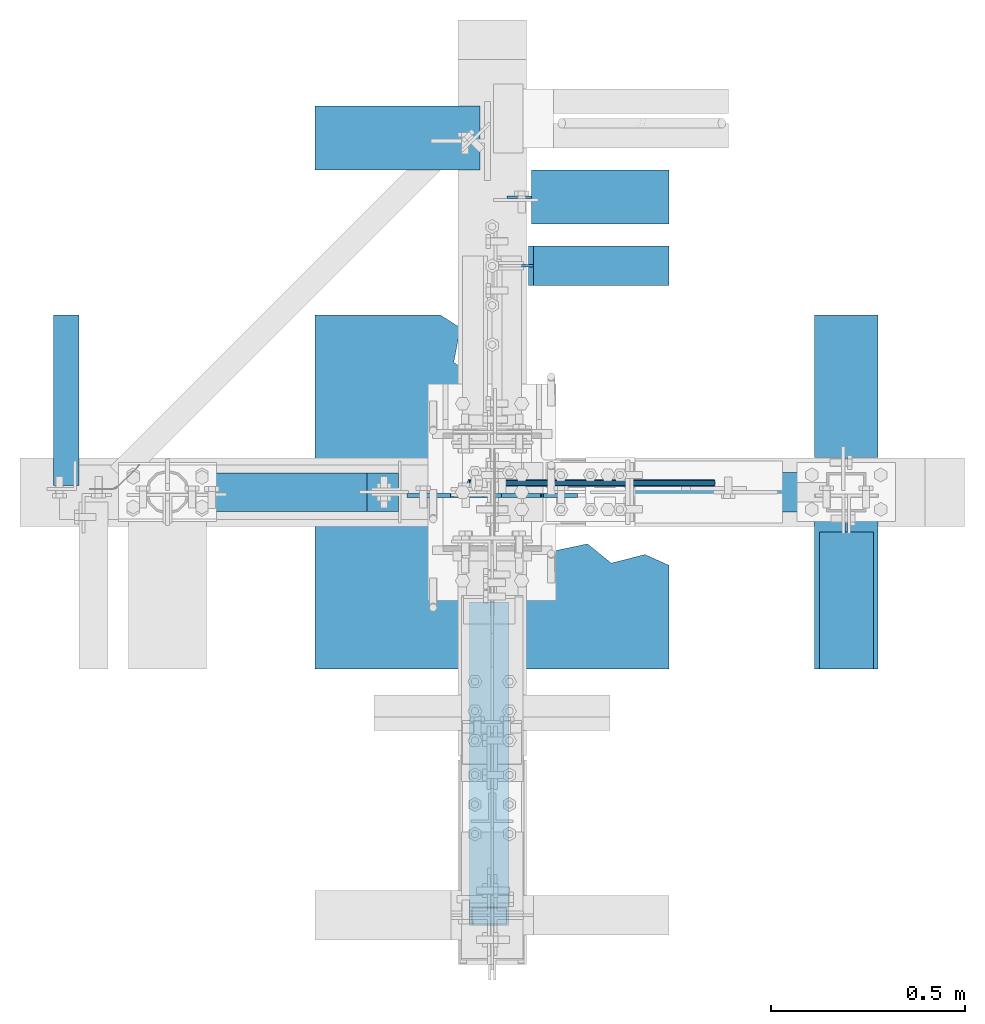
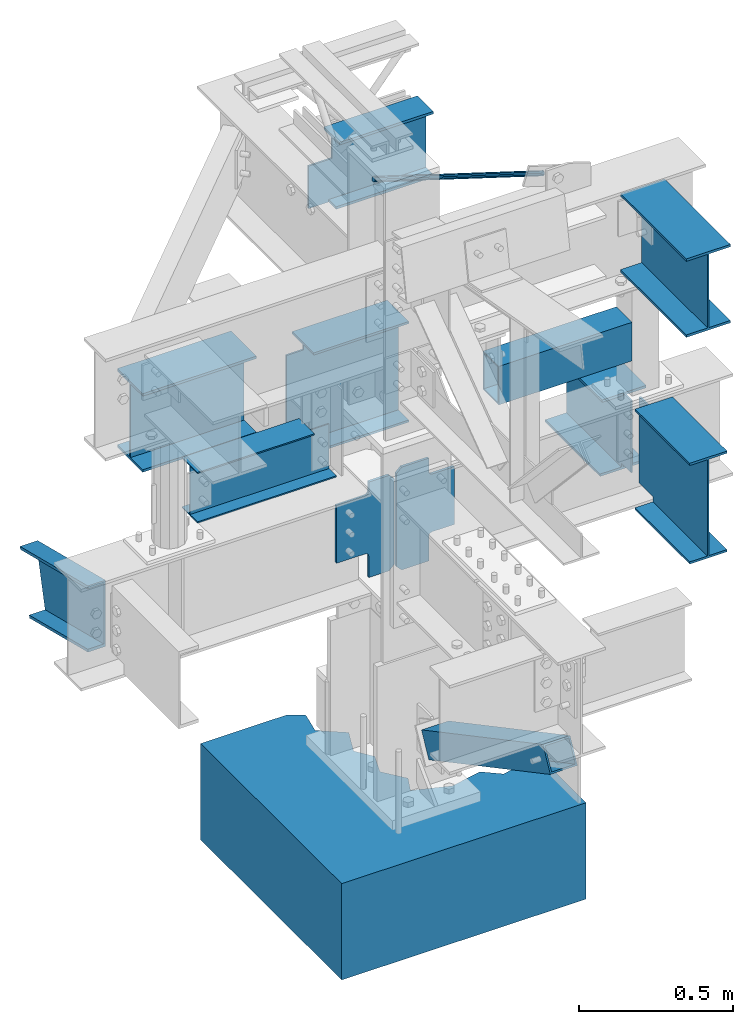
# Not in any storey, part 8 of 8: 8 beams, 3 members, 3 plates, 13 elements without a shape of their own.
"""IFC2X3 building model written with IfcOpenShell, lengths in inches."""

from ifc_helpers import new_model, entity, si_unit, converted_unit, frame, origin_with_axes, place, context, project, spatial, faceted_brep, source, transform, mapped, material, type_object, type_shapes, element, aggregate, save


model = new_model("IFC2X3")

# Units and contexts
model_context = context("Model", 3, precision=1e-05, world=origin_with_axes())
ifc_project = project(units=[converted_unit("LENGTHUNIT", "INCH", entity("IfcLengthMeasure", 25.4), si_unit("LENGTHUNIT", "METRE", prefix="MILLI"), dimensions=[1, 0, 0, 0, 0, 0, 0]), si_unit("PLANEANGLEUNIT", "RADIAN"), si_unit("MASSUNIT", "GRAM", prefix="KILO"), si_unit("TIMEUNIT", "SECOND"), si_unit("AREAUNIT", "SQUARE_METRE"), si_unit("PRESSUREUNIT", "PASCAL"), si_unit("FORCEUNIT", "NEWTON"), si_unit("THERMODYNAMICTEMPERATUREUNIT", "DEGREE_CELSIUS")], contexts=[model_context])

# Site, building
site_placement = place(None, origin_with_axes())
site = spatial("IfcSite", under=ifc_project, at=site_placement, CompositionType="ELEMENT")
building_placement = place(site_placement, origin_with_axes())
building = spatial("IfcBuilding", under=site, at=building_placement, Name="Building", CompositionType="ELEMENT")

# Assembly, member
assembly_1_placement = place(building_placement, frame((23.9999999999998, 0.9375, 83.0), z_axis=(0.0, 1.0, 0.0), x_axis=(-0.954479957764932, 0.0, 0.29827505800024)))
assembly_1 = element("IfcElementAssembly", 1, at=assembly_1_placement, inside=building, Name="4-7", PredefinedType="NOTDEFINED")
ifc_material_1 = material()
member_type_1 = type_object("IfcMemberType", Name="RB3/4", PredefinedType="BRACE", material=ifc_material_1)
shared_shape_1 = source(origin_with_axes(), model_context, "Body", "Brep", [
    faceted_brep([(0.0, 0.0, 0.375), (26.1446, 0.0, 0.375), (26.1446, 0.1875, 0.325), (0.0, 0.1875, 0.325), (26.1446, 0.3248, 0.187), (0.0, 0.3248, 0.187), (26.1446, 0.375, 0.0), (0.0, 0.375, 0.0), (26.1446, 0.3248, -0.188), (0.0, 0.3248, -0.188), (26.1446, 0.1875, -0.325), (0.0, 0.1875, -0.325), (26.1446, 0.0, -0.375), (0.0, 0.0, -0.375), (26.1446, -0.1875, -0.325), (0.0, -0.1875, -0.325), (26.1446, -0.3248, -0.187), (0.0, -0.3248, -0.187), (26.1446, -0.375, 0.0), (0.0, -0.375, 0.0), (26.1446, -0.3248, 0.188), (0.0, -0.3248, 0.188), (26.1446, -0.1875, 0.325), (0.0, -0.1875, 0.325)], [[[0, 1, 2, 3]], [[3, 2, 4, 5]], [[5, 4, 6, 7]], [[7, 6, 8, 9]], [[9, 8, 10, 11]], [[11, 10, 12, 13]], [[13, 12, 14, 15]], [[15, 14, 16, 17]], [[17, 16, 18, 19]], [[19, 18, 20, 21]], [[21, 20, 22, 23]], [[23, 22, 1, 0]], [[0, 3, 5, 7, 9, 11, 13, 15, 17, 19, 21, 23]], [[22, 20, 18, 16, 14, 12, 10, 8, 6, 4, 2, 1]]]),
])
type_shapes(member_type_1, [shared_shape_1])
member_1_placement = place(assembly_1_placement, frame((1.50000073203523, 0.0, 0.0), z_axis=(0.0, 0.0, -1.0), x_axis=(1.0, 0.0, 0.0)))
member_1 = element("IfcMember", 2, at=member_1_placement, type_object=member_type_1, Name="rb5", ObjectType="Vertical brace", context=model_context, shape_type="MappedRepresentation", body=[
    mapped(shared_shape_1, transform((0.0, 0.0, 0.0), scale=1.0)),
])
aggregate(assembly_1, [member_1])

# Assembly, beam
assembly_2_placement = place(building_placement, frame((-9.25, 0.0, 57.0), z_axis=(0.0, 0.0, 1.0), x_axis=(-1.0, 0.0, 0.0)))
assembly_2 = element("IfcElementAssembly", 3, at=assembly_2_placement, inside=building, Name="3-13", PredefinedType="NOTDEFINED")
ifc_material_2 = material()
beam_type_1 = type_object("IfcBeamType", Name="W8x10", PredefinedType="BEAM", material=ifc_material_2)
shared_shape_2 = source(origin_with_axes(), model_context, "Body", "Brep", [
    faceted_brep([(3.25, -1.97, 0.0), (3.25, 1.97, 0.0), (3.25, 1.97, -0.205), (3.25, -1.97, -0.205), (20.5, 1.97, 0.0), (20.5, 1.97, -0.205), (20.5, -1.97, 0.0), (20.5, -1.97, -0.205), (3.25, -0.085, -0.75), (3.25, 0.085, -0.75), (0.0, 0.085, -0.75), (0.0, -0.085, -0.75), (0.0, 0.085, -4.319), (0.0, -0.085, -4.319), (0.0, 0.085, -7.685), (0.0, -0.085, -7.685), (10.045, 0.085, -7.685), (10.045, -0.085, -7.685), (10.455, 0.085, -7.685), (10.455, -0.085, -7.685), (20.5, 0.085, -7.685), (20.5, -0.085, -7.685), (20.5, 0.085, -4.319), (20.5, -0.085, -4.319), (20.5, 0.085, -3.571), (20.5, -0.085, -3.571), (20.5, 0.085, -0.205), (20.5, -0.085, -0.205), (10.455, 0.085, -0.205), (10.455, -0.085, -0.205), (3.25, 0.085, -0.205), (3.25, -0.085, -0.205), (0.0, -1.97, -7.685), (0.0, 1.97, -7.685), (0.0, 1.97, -7.89), (0.0, -1.97, -7.89), (20.5, 1.97, -7.685), (20.5, 1.97, -7.89), (20.5, -1.97, -7.685), (20.5, -1.97, -7.89)], [[[0, 1, 2, 3]], [[1, 4, 5, 2]], [[4, 6, 7, 5]], [[6, 0, 3, 7]], [[6, 4, 1, 0]], [[3, 2, 5, 7]], [[8, 9, 10, 11]], [[11, 10, 12, 13]], [[13, 12, 14, 15]], [[15, 14, 16, 17]], [[17, 16, 18, 19]], [[19, 18, 20, 21]], [[21, 20, 22, 23]], [[23, 22, 24, 25]], [[25, 24, 26, 27]], [[27, 26, 28, 29]], [[29, 28, 30, 31]], [[8, 31, 30, 9]], [[8, 11, 13, 15, 17, 19, 21, 23, 25, 27, 29, 31]], [[26, 24, 22, 20, 18, 16, 14, 12, 10, 9, 30, 28]], [[32, 33, 34, 35]], [[33, 36, 37, 34]], [[36, 38, 39, 37]], [[38, 32, 35, 39]], [[38, 36, 33, 32]], [[35, 34, 37, 39]]]),
])
type_shapes(beam_type_1, [shared_shape_2])
beam_1_placement = place(assembly_2_placement, frame((0.25, 0.0, 0.0), z_axis=(0.0, 0.0, 1.0), x_axis=(1.0, 0.0, 0.0)))
beam_1 = element("IfcBeam", 4, at=beam_1_placement, type_object=beam_type_1, Name="w8", ObjectType="Beam", context=model_context, shape_type="MappedRepresentation", body=[
    mapped(shared_shape_2, transform((0.0, 0.0, 0.0), scale=1.0)),
])
aggregate(assembly_2, [beam_1])

assembly_3_placement = place(building_placement, frame((36.0, 0.0, 58.0), z_axis=(0.0, 0.0, 1.0), x_axis=(-1.0, 0.0, 0.0)))
assembly_3 = element("IfcElementAssembly", 5, at=assembly_3_placement, inside=building, Name="4-3", PredefinedType="NOTDEFINED")
ifc_material_3 = material()
beam_type_2 = type_object("IfcBeamType", Name="TS6x4x1/4", PredefinedType="BEAM", material=ifc_material_3)
shared_shape_3 = source(origin_with_axes(), model_context, "Body", "Brep", [
    faceted_brep([(0.0, -2.0, 0.0), (19.625, -2.0, 0.0), (19.625, 2.0, 0.0), (0.0, 2.0, 0.0), (0.0, -2.0, -6.0), (19.625, -2.0, -6.0), (0.0, 2.0, -6.0), (19.625, 2.0, -6.0), (0.0, -1.75, -0.25), (0.0, 1.75, -0.25), (19.625, 1.75, -0.25), (19.625, -1.75, -0.25), (0.0, 1.75, -5.75), (19.625, 1.75, -5.75), (0.0, -1.75, -5.75), (19.625, -1.75, -5.75)], [[[0, 1, 2, 3]], [[4, 5, 1, 0]], [[6, 7, 5, 4]], [[3, 2, 7, 6]], [[8, 9, 10, 11]], [[9, 12, 13, 10]], [[12, 14, 15, 13]], [[14, 8, 11, 15]], [[0, 3, 9, 8]], [[3, 6, 12, 9]], [[6, 4, 14, 12]], [[4, 0, 8, 14]], [[1, 5, 15, 11]], [[2, 1, 11, 10]], [[7, 2, 10, 13]], [[5, 7, 13, 15]]]),
])
type_shapes(beam_type_2, [shared_shape_3])
beam_2_placement = place(assembly_3_placement, frame((21.625, 0.0, 0.0), z_axis=(0.0, 0.0, 1.0), x_axis=(-1.0, 0.0, 0.0)))
beam_2 = element("IfcBeam", 6, at=beam_2_placement, type_object=beam_type_2, Name="ts3", ObjectType="Beam", context=model_context, shape_type="MappedRepresentation", body=[
    mapped(shared_shape_3, transform((0.0, 0.0, 0.0), scale=1.0)),
])
aggregate(assembly_3, [beam_2])

assembly_4_placement = place(building_placement, frame((36.0, 0.0, 46.0), z_axis=(0.0, 0.0, 1.0), x_axis=(0.0, -1.0, 0.0)))
assembly_4 = element("IfcElementAssembly", 7, at=assembly_4_placement, inside=building, Name="3-1", PredefinedType="NOTDEFINED")
beam_type_3 = type_object("IfcBeamType", Name="W16x26", PredefinedType="BEAM", material=ifc_material_2)
shared_shape_4 = source(origin_with_axes(), model_context, "Body", "Brep", [
    faceted_brep([(3.5, -2.75, 0.0), (3.5, 2.75, 0.0), (3.5, 2.75, -0.345), (3.5, -2.75, -0.345), (17.4375, 2.75, 0.0), (17.4375, 2.75, -0.345), (17.4375, -2.75, 0.0), (17.4375, -2.75, -0.345), (3.5, -0.125, -1.125), (3.5, 0.125, -1.125), (0.0, 0.125, -1.125), (0.0, -0.125, -1.125), (0.0, 0.125, -14.565), (0.0, -0.125, -14.565), (3.5, 0.125, -14.565), (3.5, -0.125, -14.565), (3.5, 0.125, -15.345), (3.5, -0.125, -15.345), (8.893, 0.125, -15.345), (8.893, -0.125, -15.345), (17.4375, 0.125, -15.345), (17.4375, -0.125, -15.345), (17.4375, 0.125, -8.595), (17.4375, -0.125, -8.595), (17.4375, 0.125, -7.095), (17.4375, -0.125, -7.095), (17.4375, 0.125, -0.345), (17.4375, -0.125, -0.345), (8.893, 0.125, -0.345), (8.893, -0.125, -0.345), (3.5, 0.125, -0.345), (3.5, -0.125, -0.345), (3.5, -2.75, -15.345), (3.5, 2.75, -15.345), (3.5, 2.75, -15.69), (3.5, -2.75, -15.69), (17.4375, 2.75, -15.345), (17.4375, 2.75, -15.69), (17.4375, -2.75, -15.345), (17.4375, -2.75, -15.69)], [[[0, 1, 2, 3]], [[1, 4, 5, 2]], [[4, 6, 7, 5]], [[6, 0, 3, 7]], [[6, 4, 1, 0]], [[3, 2, 5, 7]], [[8, 9, 10, 11]], [[11, 10, 12, 13]], [[13, 12, 14, 15]], [[15, 14, 16, 17]], [[17, 16, 18, 19]], [[19, 18, 20, 21]], [[21, 20, 22, 23]], [[23, 22, 24, 25]], [[25, 24, 26, 27]], [[27, 26, 28, 29]], [[29, 28, 30, 31]], [[8, 31, 30, 9]], [[8, 11, 13, 15, 17, 19, 21, 23, 25, 27, 29, 31]], [[26, 24, 22, 20, 18, 16, 14, 12, 10, 9, 30, 28]], [[32, 33, 34, 35]], [[33, 36, 37, 34]], [[36, 38, 39, 37]], [[38, 32, 35, 39]], [[38, 36, 33, 32]], [[35, 34, 37, 39]]]),
])
type_shapes(beam_type_3, [shared_shape_4])
beam_3_placement = place(assembly_4_placement, frame((0.5625, 0.0, 0.0), z_axis=(0.0, 0.0, 1.0), x_axis=(1.0, 0.0, 0.0)))
beam_3 = element("IfcBeam", 8, at=beam_3_placement, type_object=beam_type_3, Name="w3", ObjectType="Beam", context=model_context, shape_type="MappedRepresentation", body=[
    mapped(shared_shape_4, transform((0.0, 0.0, 0.0), scale=1.0)),
])
aggregate(assembly_4, [beam_3])

assembly_5_placement = place(building_placement, frame((36.0, 0.0, 43.0), z_axis=(0.0, 0.0, 1.0), x_axis=(0.0, 1.0, 0.0)))
assembly_5 = element("IfcElementAssembly", 9, at=assembly_5_placement, inside=building, Name="3-3", PredefinedType="NOTDEFINED")
beam_type_4 = type_object("IfcBeamType", Name="W12x26", PredefinedType="BEAM", material=ifc_material_2)
shared_shape_5 = source(origin_with_axes(), model_context, "Body", "Brep", [
    faceted_brep([(2.0, -0.115, 0.0), (0.0, -0.115, 0.0), (0.0, -0.115, -0.38), (2.0, -0.115, -0.38), (0.0, 0.115, 0.0), (0.0, 0.115, -0.38), (2.0, 0.115, 0.0), (2.0, 0.115, -0.38), (2.0, 3.245, 0.0), (2.0, 3.245, -0.38), (8.415, 3.245, 0.0), (8.415, 3.245, -0.38), (16.5, 3.245, 0.0), (16.5, 3.245, -0.38), (16.5, 0.325, 0.0), (16.5, 0.325, -0.38), (16.5, -0.325, 0.0), (16.5, -0.325, -0.38), (16.5, -3.245, 0.0), (16.5, -3.245, -0.38), (8.415, -3.245, 0.0), (8.415, -3.245, -0.38), (2.0, -3.245, 0.0), (2.0, -3.245, -0.38), (0.0, -0.115, -0.38), (0.0, 0.115, -0.38), (0.0, 0.115, -3.13), (0.0, -0.115, -3.13), (0.0, 0.115, -11.22), (0.0, -0.115, -11.22), (2.5, 0.115, -11.22), (2.5, -0.115, -11.22), (2.5, 0.115, -11.84), (2.5, -0.115, -11.84), (8.415, 0.115, -11.84), (8.415, -0.115, -11.84), (16.5, 0.115, -11.84), (16.5, -0.115, -11.84), (16.5, 0.115, -6.683), (16.5, -0.115, -6.683), (16.5, 0.115, -5.537), (16.5, -0.115, -5.537), (16.5, 0.115, -0.38), (16.5, -0.115, -0.38), (8.415, 0.115, -0.38), (8.415, -0.115, -0.38), (8.085, 0.115, -0.38), (8.085, -0.115, -0.38), (2.5, -3.245, -11.84), (2.5, -0.325, -11.84), (2.5, -0.325, -12.22), (2.5, -3.245, -12.22), (2.5, 0.325, -11.84), (2.5, 0.325, -12.22), (2.5, 3.245, -11.84), (2.5, 3.245, -12.22), (8.085, 3.245, -11.84), (8.085, 3.245, -12.22), (8.415, 3.245, -11.84), (8.415, 3.245, -12.22), (16.5, 3.245, -11.84), (16.5, 3.245, -12.22), (16.5, 0.325, -11.84), (16.5, 0.325, -12.22), (16.5, -0.325, -11.84), (16.5, -0.325, -12.22), (16.5, -3.245, -11.84), (16.5, -3.245, -12.22), (8.415, -3.245, -11.84), (8.415, -3.245, -12.22), (8.085, -3.245, -11.84), (8.085, -3.245, -12.22)], [[[0, 1, 2, 3]], [[1, 4, 5, 2]], [[4, 6, 7, 5]], [[6, 8, 9, 7]], [[8, 10, 11, 9]], [[10, 12, 13, 11]], [[12, 14, 15, 13]], [[14, 16, 17, 15]], [[16, 18, 19, 17]], [[18, 20, 21, 19]], [[20, 22, 23, 21]], [[22, 0, 3, 23]], [[18, 16, 14, 12, 10, 8, 6, 4, 1, 0, 22, 20]], [[3, 2, 5, 7, 9, 11, 13, 15, 17, 19, 21, 23]], [[24, 25, 26, 27]], [[27, 26, 28, 29]], [[29, 28, 30, 31]], [[31, 30, 32, 33]], [[33, 32, 34, 35]], [[35, 34, 36, 37]], [[37, 36, 38, 39]], [[39, 38, 40, 41]], [[41, 40, 42, 43]], [[43, 42, 44, 45]], [[45, 44, 46, 47]], [[24, 47, 46, 25]], [[24, 27, 29, 31, 33, 35, 37, 39, 41, 43, 45, 47]], [[42, 40, 38, 36, 34, 32, 30, 28, 26, 25, 46, 44]], [[48, 49, 50, 51]], [[49, 52, 53, 50]], [[52, 54, 55, 53]], [[54, 56, 57, 55]], [[56, 58, 59, 57]], [[58, 60, 61, 59]], [[60, 62, 63, 61]], [[62, 64, 65, 63]], [[64, 66, 67, 65]], [[66, 68, 69, 67]], [[68, 70, 71, 69]], [[70, 48, 51, 71]], [[66, 64, 62, 60, 58, 56, 54, 52, 49, 48, 70, 68]], [[51, 50, 53, 55, 57, 59, 61, 63, 65, 67, 69, 71]]]),
])
type_shapes(beam_type_4, [shared_shape_5])
beam_4_placement = place(assembly_5_placement, frame((1.5, 0.0, 0.0), z_axis=(0.0, 0.0, 1.0), x_axis=(1.0, 0.0, 0.0)))
beam_4 = element("IfcBeam", 10, at=beam_4_placement, type_object=beam_type_4, Name="w13", ObjectType="Beam", context=model_context, shape_type="MappedRepresentation", body=[
    mapped(shared_shape_5, transform((0.0, 0.0, 0.0), scale=1.0)),
])
aggregate(assembly_5, [beam_4])

assembly_6_placement = place(building_placement, frame((0.0, 30.0, 46.0), z_axis=(0.0, 0.0, 1.0), x_axis=(1.0, 0.0, 0.0)))
assembly_6 = element("IfcElementAssembly", 11, at=assembly_6_placement, inside=building, Name="3-2", PredefinedType="NOTDEFINED")
beam_type_5 = type_object("IfcBeamType", Name="W16x26", PredefinedType="BEAM", material=ifc_material_2)
shared_shape_6 = source(origin_with_axes(), model_context, "Body", "Brep", [
    faceted_brep([(2.5, -2.75, 0.0), (2.5, 2.75, 0.0), (2.5, 2.75, -0.345), (2.5, -2.75, -0.345), (16.5, 2.75, 0.0), (16.5, 2.75, -0.345), (16.5, -2.75, 0.0), (16.5, -2.75, -0.345), (2.5, -0.125, -1.125), (2.5, 0.125, -1.125), (0.0, 0.125, -1.125), (0.0, -0.125, -1.125), (0.0, 0.125, -14.565), (0.0, -0.125, -14.565), (2.5, 0.125, -14.565), (2.5, -0.125, -14.565), (2.5, 0.125, -15.345), (2.5, -0.125, -15.345), (8.415, 0.125, -15.345), (8.415, -0.125, -15.345), (16.5, 0.125, -15.345), (16.5, -0.125, -15.345), (16.5, 0.125, -8.595), (16.5, -0.125, -8.595), (16.5, 0.125, -7.095), (16.5, -0.125, -7.095), (16.5, 0.125, -0.345), (16.5, -0.125, -0.345), (8.415, 0.125, -0.345), (8.415, -0.125, -0.345), (2.5, 0.125, -0.345), (2.5, -0.125, -0.345), (2.5, -2.75, -15.345), (2.5, 2.75, -15.345), (2.5, 2.75, -15.69), (2.5, -2.75, -15.69), (16.5, 2.75, -15.345), (16.5, 2.75, -15.69), (16.5, -2.75, -15.345), (16.5, -2.75, -15.69)], [[[0, 1, 2, 3]], [[1, 4, 5, 2]], [[4, 6, 7, 5]], [[6, 0, 3, 7]], [[6, 4, 1, 0]], [[3, 2, 5, 7]], [[8, 9, 10, 11]], [[11, 10, 12, 13]], [[13, 12, 14, 15]], [[15, 14, 16, 17]], [[17, 16, 18, 19]], [[19, 18, 20, 21]], [[21, 20, 22, 23]], [[23, 22, 24, 25]], [[25, 24, 26, 27]], [[27, 26, 28, 29]], [[29, 28, 30, 31]], [[8, 31, 30, 9]], [[8, 11, 13, 15, 17, 19, 21, 23, 25, 27, 29, 31]], [[26, 24, 22, 20, 18, 16, 14, 12, 10, 9, 30, 28]], [[32, 33, 34, 35]], [[33, 36, 37, 34]], [[36, 38, 39, 37]], [[38, 32, 35, 39]], [[38, 36, 33, 32]], [[35, 34, 37, 39]]]),
])
type_shapes(beam_type_5, [shared_shape_6])
beam_5_placement = place(assembly_6_placement, frame((1.5, 0.0, 0.0), z_axis=(0.0, 0.0, 1.0), x_axis=(1.0, 0.0, 0.0)))
beam_5 = element("IfcBeam", 12, at=beam_5_placement, type_object=beam_type_5, Name="w16", ObjectType="Beam", context=model_context, shape_type="MappedRepresentation", body=[
    mapped(shared_shape_6, transform((0.0, 0.0, 0.0), scale=1.0)),
])
aggregate(assembly_6, [beam_5])

assembly_7_placement = place(building_placement, frame((0.0, 36.0, 44.0), z_axis=(0.0, 0.0, 1.0), x_axis=(-1.0, 0.0, 0.0)))
assembly_7 = element("IfcElementAssembly", 13, at=assembly_7_placement, inside=building, Name="3-4", PredefinedType="NOTDEFINED")
beam_type_6 = type_object("IfcBeamType", Name="W12x26", PredefinedType="BEAM", material=ifc_material_2)
shared_shape_7 = source(origin_with_axes(), model_context, "Body", "Brep", [
    faceted_brep([(0.0, -3.245, -12.22), (0.0, -3.245, -11.84), (0.0, -0.115, -11.84), (0.0, -0.115, -0.38), (0.0, -3.245, -0.38), (0.0, -3.245, 0.0), (0.0, 3.245, 0.0), (0.0, 3.245, -0.38), (0.0, 0.115, -0.38), (0.0, 0.115, -11.84), (0.0, 3.245, -11.84), (0.0, 3.245, -12.22), (16.75, 3.245, -12.22), (16.75, 3.245, -11.84), (16.75, 0.115, -11.84), (16.75, 0.115, -0.38), (16.75, 3.245, -0.38), (16.75, 3.245, 0.0), (16.75, -3.245, 0.0), (16.75, -3.245, -0.38), (16.75, -0.115, -0.38), (16.75, -0.115, -11.84), (16.75, -3.245, -11.84), (16.75, -3.245, -12.22)], [[[0, 1, 2, 3, 4, 5, 6, 7, 8, 9, 10, 11]], [[12, 13, 14, 15, 16, 17, 18, 19, 20, 21, 22, 23]], [[0, 23, 22, 1]], [[1, 22, 21, 2]], [[2, 21, 20, 3]], [[3, 20, 19, 4]], [[4, 19, 18, 5]], [[5, 18, 17, 6]], [[6, 17, 16, 7]], [[7, 16, 15, 8]], [[8, 15, 14, 9]], [[9, 14, 13, 10]], [[10, 13, 12, 11]], [[11, 12, 23, 0]]]),
])
type_shapes(beam_type_6, [shared_shape_7])
beam_6_placement = place(assembly_7_placement, frame((1.25, 0.0, 0.0), z_axis=(0.0, 0.0, 1.0), x_axis=(1.0, 0.0, 0.0)))
beam_6 = element("IfcBeam", 14, at=beam_6_placement, type_object=beam_type_6, Name="w18", ObjectType="Beam", context=model_context, shape_type="MappedRepresentation", body=[
    mapped(shared_shape_7, transform((0.0, 0.0, 0.0), scale=1.0)),
])
aggregate(assembly_7, [beam_6])

# Assembly, member
assembly_8_placement = place(building_placement, frame((-42.0, 0.0, 43.0), z_axis=(0.0, 0.242535628120103, 0.970142499374389), x_axis=(0.0, 0.970142499374388, -0.242535628120103)))
assembly_8 = element("IfcElementAssembly", 15, at=assembly_8_placement, inside=building, Name="3-8", PredefinedType="NOTDEFINED")
ifc_material_4 = material()
member_type_2 = type_object("IfcMemberType", Name="C10x15.3", PredefinedType="USERDEFINED", material=ifc_material_4)
shared_shape_8 = source(origin_with_axes(), model_context, "Body", "Brep", [
    faceted_brep([(0.0, 0.0, 0.0), (0.0, 2.6, 0.0), (0.109, 2.6, -0.436), (0.109, 0.0, -0.436), (17.8453, 2.6, 0.0), (17.8453, 2.6, -0.436), (17.8453, 0.0, 0.0), (17.8453, 0.0, -0.436), (0.109, 0.0, -0.436), (0.109, 0.24, -0.436), (2.392, 0.24, -9.564), (2.392, 0.0, -9.564), (17.8453, 0.24, -0.436), (17.8453, 0.24, -9.564), (17.8453, 0.0, -0.436), (17.8453, 0.0, -9.564), (2.392, 0.0, -9.564), (2.392, 2.6, -9.564), (2.501, 2.6, -10.0), (2.501, 0.0, -10.0), (17.8453, 2.6, -9.564), (17.8453, 2.6, -10.0), (17.8453, 0.0, -9.564), (17.8453, 0.0, -10.0)], [[[0, 1, 2, 3]], [[1, 4, 5, 2]], [[4, 6, 7, 5]], [[6, 0, 3, 7]], [[6, 4, 1, 0]], [[3, 2, 5, 7]], [[8, 9, 10, 11]], [[9, 12, 13, 10]], [[12, 14, 15, 13]], [[14, 8, 11, 15]], [[14, 12, 9, 8]], [[11, 10, 13, 15]], [[16, 17, 18, 19]], [[17, 20, 21, 18]], [[20, 22, 23, 21]], [[22, 16, 19, 23]], [[22, 20, 17, 16]], [[19, 18, 21, 23]]]),
])
type_shapes(member_type_2, [shared_shape_8])
member_2_placement = place(assembly_8_placement, frame((0.708658754825592, 0.0, 0.0), z_axis=(0.0, 0.0, 1.0), x_axis=(1.0, 0.0, 0.0)))
member_2 = element("IfcMember", 16, at=member_2_placement, type_object=member_type_2, Name="c1", ObjectType="Beam", context=model_context, shape_type="MappedRepresentation", body=[
    mapped(shared_shape_8, transform((0.0, 0.0, 0.0), scale=1.0)),
])
aggregate(assembly_8, [member_2])

# Assembly, beam
assembly_9_placement = place(building_placement, frame((36.0, 0.0, 78.0), z_axis=(0.0, 0.0, 1.0), x_axis=(0.0, -1.0, 0.0)))
assembly_9 = element("IfcElementAssembly", 17, at=assembly_9_placement, inside=building, Name="3-9", PredefinedType="NOTDEFINED")
beam_type_7 = type_object("IfcBeamType", Name="W12x26", PredefinedType="BEAM", material=ifc_material_2)
shared_shape_9 = source(origin_with_axes(), model_context, "Body", "Brep", [
    faceted_brep([(0.0, -3.245, -12.22), (0.0, -3.245, -11.84), (0.0, -0.115, -11.84), (0.0, -0.115, -0.38), (0.0, -3.245, -0.38), (0.0, -3.245, 0.0), (0.0, 3.245, 0.0), (0.0, 3.245, -0.38), (0.0, 0.115, -0.38), (0.0, 0.115, -11.84), (0.0, 3.245, -11.84), (0.0, 3.245, -12.22), (16.8125, 3.245, -12.22), (16.8125, 3.245, -11.84), (16.8125, 0.115, -11.84), (16.8125, 0.115, -0.38), (16.8125, 3.245, -0.38), (16.8125, 3.245, 0.0), (16.8125, -3.245, 0.0), (16.8125, -3.245, -0.38), (16.8125, -0.115, -0.38), (16.8125, -0.115, -11.84), (16.8125, -3.245, -11.84), (16.8125, -3.245, -12.22)], [[[0, 1, 2, 3, 4, 5, 6, 7, 8, 9, 10, 11]], [[12, 13, 14, 15, 16, 17, 18, 19, 20, 21, 22, 23]], [[0, 23, 22, 1]], [[1, 22, 21, 2]], [[2, 21, 20, 3]], [[3, 20, 19, 4]], [[4, 19, 18, 5]], [[5, 18, 17, 6]], [[6, 17, 16, 7]], [[7, 16, 15, 8]], [[8, 15, 14, 9]], [[9, 14, 13, 10]], [[10, 13, 12, 11]], [[11, 12, 23, 0]]]),
])
type_shapes(beam_type_7, [shared_shape_9])
beam_7_placement = place(assembly_9_placement, frame((1.1875, 0.0, 0.0), z_axis=(0.0, 0.0, 1.0), x_axis=(1.0, 0.0, 0.0)))
beam_7 = element("IfcBeam", 18, at=beam_7_placement, type_object=beam_type_7, Name="w2", ObjectType="Beam", context=model_context, shape_type="MappedRepresentation", body=[
    mapped(shared_shape_9, transform((0.0, 0.0, 0.0), scale=1.0)),
])
aggregate(assembly_9, [beam_7])

assembly_10_placement = place(building_placement, frame((0.0, 23.0, 82.5), z_axis=(0.0, 0.0, 1.0), x_axis=(1.0, 0.0, 0.0)))
assembly_10 = element("IfcElementAssembly", 19, at=assembly_10_placement, inside=building, Name="3-11", PredefinedType="NOTDEFINED")
beam_type_8 = type_object("IfcBeamType", Name="W10x19", PredefinedType="BEAM", material=ifc_material_2)
shared_shape_10 = source(origin_with_axes(), model_context, "Body", "Brep", [
    faceted_brep([(3.5, -2.01, 0.0), (3.5, -0.201, 0.0), (3.5, -0.201, -0.395), (3.5, -2.01, -0.395), (3.5, 0.201, 0.0), (3.5, 0.201, -0.395), (3.5, 2.01, 0.0), (3.5, 2.01, -0.395), (8.483, 2.01, 0.0), (8.483, 2.01, -0.395), (8.829, 2.01, 0.0), (8.829, 2.01, -0.395), (17.3125, 2.01, 0.0), (17.3125, 2.01, -0.395), (17.3125, 0.201, 0.0), (17.3125, 0.201, -0.395), (17.3125, -0.201, 0.0), (17.3125, -0.201, -0.395), (17.3125, -2.01, 0.0), (17.3125, -2.01, -0.395), (8.829, -2.01, 0.0), (8.829, -2.01, -0.395), (8.483, -2.01, 0.0), (8.483, -2.01, -0.395), (3.5, -0.125, -3.625), (3.5, 0.125, -3.625), (0.0, 0.125, -3.625), (0.0, -0.125, -3.625), (0.0, 0.125, -8.355), (0.0, -0.125, -8.355), (0.0, 0.125, -9.845), (0.0, -0.125, -9.845), (8.483, 0.125, -9.845), (8.483, -0.125, -9.845), (8.829, 0.125, -9.845), (8.829, -0.125, -9.845), (17.3125, 0.125, -9.845), (17.3125, -0.125, -9.845), (17.3125, 0.125, -5.593), (17.3125, -0.125, -5.593), (17.3125, 0.125, -4.648), (17.3125, -0.125, -4.648), (17.3125, 0.125, -0.395), (17.3125, -0.125, -0.395), (8.829, 0.125, -0.395), (8.829, -0.125, -0.395), (3.5, 0.125, -0.395), (3.5, -0.125, -0.395), (3.0, -0.125, -9.845), (0.0, -0.125, -9.845), (0.0, -0.125, -10.24), (3.0, -0.125, -10.24), (0.0, 0.125, -9.845), (0.0, 0.125, -10.24), (3.0, 0.125, -9.845), (3.0, 0.125, -10.24), (3.0, 2.01, -9.845), (3.0, 2.01, -10.24), (8.829, 2.01, -9.845), (8.829, 2.01, -10.24), (17.3125, 2.01, -9.845), (17.3125, 2.01, -10.24), (17.3125, 0.201, -9.845), (17.3125, 0.201, -10.24), (17.3125, -0.201, -9.845), (17.3125, -0.201, -10.24), (17.3125, -2.01, -9.845), (17.3125, -2.01, -10.24), (8.829, -2.01, -9.845), (8.829, -2.01, -10.24), (3.0, -2.01, -9.845), (3.0, -2.01, -10.24)], [[[0, 1, 2, 3]], [[1, 4, 5, 2]], [[4, 6, 7, 5]], [[6, 8, 9, 7]], [[8, 10, 11, 9]], [[10, 12, 13, 11]], [[12, 14, 15, 13]], [[14, 16, 17, 15]], [[16, 18, 19, 17]], [[18, 20, 21, 19]], [[20, 22, 23, 21]], [[22, 0, 3, 23]], [[18, 16, 14, 12, 10, 8, 6, 4, 1, 0, 22, 20]], [[3, 2, 5, 7, 9, 11, 13, 15, 17, 19, 21, 23]], [[24, 25, 26, 27]], [[27, 26, 28, 29]], [[29, 28, 30, 31]], [[31, 30, 32, 33]], [[33, 32, 34, 35]], [[35, 34, 36, 37]], [[37, 36, 38, 39]], [[39, 38, 40, 41]], [[41, 40, 42, 43]], [[43, 42, 44, 45]], [[45, 44, 46, 47]], [[24, 47, 46, 25]], [[24, 27, 29, 31, 33, 35, 37, 39, 41, 43, 45, 47]], [[42, 40, 38, 36, 34, 32, 30, 28, 26, 25, 46, 44]], [[48, 49, 50, 51]], [[49, 52, 53, 50]], [[52, 54, 55, 53]], [[54, 56, 57, 55]], [[56, 58, 59, 57]], [[58, 60, 61, 59]], [[60, 62, 63, 61]], [[62, 64, 65, 63]], [[64, 66, 67, 65]], [[66, 68, 69, 67]], [[68, 70, 71, 69]], [[70, 48, 51, 71]], [[66, 64, 62, 60, 58, 56, 54, 52, 49, 48, 70, 68]], [[51, 50, 53, 55, 57, 59, 61, 63, 65, 67, 69, 71]]]),
])
type_shapes(beam_type_8, [shared_shape_10])
beam_8_placement = place(assembly_10_placement, frame((0.6875, 0.0, 0.0), z_axis=(0.0, 0.0, 1.0), x_axis=(1.0, 0.0, 0.0)))
beam_8 = element("IfcBeam", 20, at=beam_8_placement, type_object=beam_type_8, Name="w17", ObjectType="Beam", context=model_context, shape_type="MappedRepresentation", body=[
    mapped(shared_shape_10, transform((0.0, 0.0, 0.0), scale=1.0)),
])
aggregate(assembly_10, [beam_8])

# Assembly, member
assembly_11_placement = place(building_placement, frame((-0.302501678466797, -6.35499954223631, 7.97817420959473), z_axis=(0.0, 0.470283939984076, 0.882515164624979), x_axis=(0.0, -0.882515164624978, 0.470283939984076)))
assembly_11 = element("IfcElementAssembly", 21, at=assembly_11_placement, inside=building, Name="4-6", PredefinedType="NOTDEFINED")
member_type_3 = type_object("IfcMemberType", Name="TS4x4x1/4", PredefinedType="BRACE", material=ifc_material_3)
shared_shape_11 = source(origin_with_axes(), model_context, "Body", "Brep", [
    faceted_brep([(0.0, -2.0, 2.0), (35.1265, -2.0, 2.0), (35.1265, 2.0, 2.0), (0.0, 2.0, 2.0), (0.0, -2.0, -2.0), (35.1265, -2.0, -2.0), (0.0, 2.0, -2.0), (35.1265, 2.0, -2.0), (0.0, -1.75, 1.75), (0.0, 1.75, 1.75), (35.1265, 1.75, 1.75), (35.1265, -1.75, 1.75), (0.0, 1.75, -1.75), (35.1265, 1.75, -1.75), (0.0, -1.75, -1.75), (35.1265, -1.75, -1.75)], [[[0, 1, 2, 3]], [[4, 5, 1, 0]], [[6, 7, 5, 4]], [[3, 2, 7, 6]], [[8, 9, 10, 11]], [[9, 12, 13, 10]], [[12, 14, 15, 13]], [[14, 8, 11, 15]], [[0, 3, 9, 8]], [[3, 6, 12, 9]], [[6, 4, 14, 12]], [[4, 0, 8, 14]], [[1, 5, 15, 11]], [[2, 1, 11, 10]], [[7, 2, 10, 13]], [[5, 7, 13, 15]]]),
])
type_shapes(member_type_3, [shared_shape_11])
member_3_placement = place(assembly_11_placement, frame((6.49999999999999, 0.0, 0.0), z_axis=(0.0, 0.0, 1.0), x_axis=(1.0, 0.0, 0.0)))
member_3 = element("IfcMember", 22, at=member_3_placement, type_object=member_type_3, Name="ts5", ObjectType="Vertical brace", context=model_context, shape_type="MappedRepresentation", body=[
    mapped(shared_shape_11, transform((0.0, 0.0, 0.0), scale=1.0)),
])
aggregate(assembly_11, [member_3])

# Assembly, plate
assembly_12_placement = place(building_placement, frame((-18.0, -18.0, -1.5), z_axis=(0.0, -1.0, 0.0), x_axis=(0.0, 0.0, 1.0)))
assembly_12 = element("IfcElementAssembly", 23, at=assembly_12_placement, inside=building, Name="M_51", PredefinedType="NOTDEFINED")
ifc_material_5 = material()
plate_type_1 = type_object("IfcPlateType", Name="Plate (Complex)", PredefinedType="SHEET", material=ifc_material_5)
shared_shape_12 = source(origin_with_axes(), model_context, "Body", "Brep", [
    faceted_brep([(-7.5, -33.52677, -11.664), (-7.5, -36.0, -10.56), (-7.5, -36.0, 0.0), (-7.5, 0.0, 0.0), (-7.5, 0.0, -36.0), (-7.5, -12.7527, -36.0), (-7.5, -14.7696, -34.715), (-7.5, -14.10268, -31.213), (-7.5, -17.60402, -28.671), (-7.5, -16.06176, -24.794), (-7.5, -17.81243, -22.418), (-7.5, -16.687, -19.125), (-7.5, -19.06291, -16.083), (-7.5, -17.97916, -13.582), (-7.5, -23.10612, -11.789), (-7.5, -27.69121, -12.748), (-7.5, -30.1088, -10.789), (7.5, -30.1088, -10.789), (7.5, -27.69121, -12.748), (7.5, -23.10612, -11.789), (7.5, -17.97916, -13.582), (7.5, -19.06291, -16.083), (7.5, -16.687, -19.125), (7.5, -17.81243, -22.418), (7.5, -16.06176, -24.794), (7.5, -17.60402, -28.671), (7.5, -14.10268, -31.213), (7.5, -14.7696, -34.715), (7.5, -12.7527, -36.0), (7.5, 0.0, -36.0), (7.5, 0.0, 0.0), (7.5, -36.0, 0.0), (7.5, -36.0, -10.56), (7.5, -33.52677, -11.664)], [[[0, 1, 2, 3, 4, 5, 6, 7, 8, 9, 10, 11, 12, 13, 14, 15, 16]], [[17, 18, 19, 20, 21, 22, 23, 24, 25, 26, 27, 28, 29, 30, 31, 32, 33]], [[33, 32, 1, 0]], [[32, 31, 2, 1]], [[31, 30, 3, 2]], [[30, 29, 4, 3]], [[29, 28, 5, 4]], [[28, 27, 6, 5]], [[27, 26, 7, 6]], [[26, 25, 8, 7]], [[25, 24, 9, 8]], [[24, 23, 10, 9]], [[23, 22, 11, 10]], [[22, 21, 12, 11]], [[21, 20, 13, 12]], [[20, 19, 14, 13]], [[19, 18, 15, 14]], [[18, 17, 16, 15]], [[17, 33, 0, 16]]]),
])
type_shapes(plate_type_1, [shared_shape_12])
plate_1_placement = place(assembly_12_placement, frame((-7.5, 0.0, 0.0), z_axis=(0.0, 0.0, 1.0), x_axis=(1.0, 0.0, 0.0)))
plate_1 = element("IfcPlate", 24, at=plate_1_placement, type_object=plate_type_1, Name="p58", ObjectType="Member", context=model_context, shape_type="MappedRepresentation", body=[
    mapped(shared_shape_12, transform((0.0, 0.0, 0.0), scale=1.0)),
])
aggregate(assembly_12, [plate_1])

# Assembly, plates
assembly_13_placement = place(building_placement, frame((0.0, 0.0, 21.0), z_axis=(0.0, -1.0, 0.0), x_axis=(0.0, 0.0, 1.0)))
assembly_13 = element("IfcElementAssembly", 25, at=assembly_13_placement, inside=building, Name="1-2", PredefinedType="NOTDEFINED")
plate_type_2 = type_object("IfcPlateType", Name="Plate (Complex)", PredefinedType="SHEET", material=ifc_material_5)
shared_shape_13 = source(origin_with_axes(), model_context, "Body", "Brep", [
    faceted_brep([(-0.1875, 0.0, -4.75), (-0.1875, -2.125, -4.75), (-0.1875, -2.31634, -4.788), (-0.1875, -2.47855, -4.896), (-0.1875, -2.58694, -5.059), (-0.1875, -2.625, -5.25), (-0.1875, -2.625, -8.5), (-0.1875, -11.625, -8.5), (-0.1875, -11.625, -5.25), (-0.1875, -11.66306, -5.059), (-0.1875, -11.77145, -4.896), (-0.1875, -11.93366, -4.788), (-0.1875, -12.125, -4.75), (-0.1875, -16.0, -4.75), (-0.1875, -16.0, -0.75), (-0.1875, -15.25, 0.0), (-0.1875, -0.75, 0.0), (-0.1875, 0.0, -0.75), (0.1875, 0.0, -0.75), (0.1875, -0.75, 0.0), (0.1875, -15.25, 0.0), (0.1875, -16.0, -0.75), (0.1875, -16.0, -4.75), (0.1875, -12.125, -4.75), (0.1875, -11.93366, -4.788), (0.1875, -11.77145, -4.896), (0.1875, -11.66306, -5.059), (0.1875, -11.625, -5.25), (0.1875, -11.625, -8.5), (0.1875, -2.625, -8.5), (0.1875, -2.625, -5.25), (0.1875, -2.58694, -5.059), (0.1875, -2.47855, -4.896), (0.1875, -2.31634, -4.788), (0.1875, -2.125, -4.75), (0.1875, 0.0, -4.75)], [[[0, 1, 2, 3, 4, 5, 6, 7, 8, 9, 10, 11, 12, 13, 14, 15, 16, 17]], [[18, 19, 20, 21, 22, 23, 24, 25, 26, 27, 28, 29, 30, 31, 32, 33, 34, 35]], [[35, 34, 1, 0]], [[34, 33, 2, 1]], [[33, 32, 3, 2]], [[32, 31, 4, 3]], [[31, 30, 5, 4]], [[30, 29, 6, 5]], [[29, 28, 7, 6]], [[28, 27, 8, 7]], [[27, 26, 9, 8]], [[26, 25, 10, 9]], [[25, 24, 11, 10]], [[24, 23, 12, 11]], [[23, 22, 13, 12]], [[22, 21, 14, 13]], [[21, 20, 15, 14]], [[20, 19, 16, 15]], [[19, 18, 17, 16]], [[18, 35, 0, 17]]]),
])
type_shapes(plate_type_2, [shared_shape_13])
plate_2_placement = place(assembly_13_placement, frame((25.125, -0.172499999403954, 0.33500000834465), z_axis=(0.0, 1.0, 0.0), x_axis=(0.0, 0.0, 1.0)))
plate_2 = element("IfcPlate", 26, at=plate_2_placement, type_object=plate_type_2, Name="p45", ObjectType="Column", context=model_context, shape_type="MappedRepresentation", body=[
    mapped(shared_shape_13, transform((0.0, 0.0, 0.0), scale=1.0)),
])
plate_type_3 = type_object("IfcPlateType", Name="Plate (Complex)", PredefinedType="SHEET", material=ifc_material_5)
shared_shape_14 = source(origin_with_axes(), model_context, "Body", "Brep", [
    faceted_brep([(-0.1875, 0.0, -3.75), (-0.1875, -1.5, -3.75), (-0.1875, -1.69134, -3.788), (-0.1875, -1.85355, -3.896), (-0.1875, -1.96194, -4.059), (-0.1875, -2.0, -4.25), (-0.1875, -2.0, -8.5), (-0.1875, -11.0, -8.5), (-0.1875, -11.0, -4.25), (-0.1875, -11.03806, -4.059), (-0.1875, -11.14645, -3.896), (-0.1875, -11.30866, -3.788), (-0.1875, -11.5, -3.75), (-0.1875, -14.875, -3.75), (-0.1875, -14.875, -0.75), (-0.1875, -14.125, 0.0), (-0.1875, -0.75, 0.0), (-0.1875, 0.0, -0.75), (0.1875, 0.0, -0.75), (0.1875, -0.75, 0.0), (0.1875, -14.125, 0.0), (0.1875, -14.875, -0.75), (0.1875, -14.875, -3.75), (0.1875, -11.5, -3.75), (0.1875, -11.30866, -3.788), (0.1875, -11.14645, -3.896), (0.1875, -11.03806, -4.059), (0.1875, -11.0, -4.25), (0.1875, -11.0, -8.5), (0.1875, -2.0, -8.5), (0.1875, -2.0, -4.25), (0.1875, -1.96194, -4.059), (0.1875, -1.85355, -3.896), (0.1875, -1.69134, -3.788), (0.1875, -1.5, -3.75), (0.1875, 0.0, -3.75)], [[[0, 1, 2, 3, 4, 5, 6, 7, 8, 9, 10, 11, 12, 13, 14, 15, 16, 17]], [[18, 19, 20, 21, 22, 23, 24, 25, 26, 27, 28, 29, 30, 31, 32, 33, 34, 35]], [[35, 34, 1, 0]], [[34, 33, 2, 1]], [[33, 32, 3, 2]], [[32, 31, 4, 3]], [[31, 30, 5, 4]], [[30, 29, 6, 5]], [[29, 28, 7, 6]], [[28, 27, 8, 7]], [[27, 26, 9, 8]], [[26, 25, 10, 9]], [[25, 24, 11, 10]], [[24, 23, 12, 11]], [[23, 22, 13, 12]], [[22, 21, 14, 13]], [[21, 20, 15, 14]], [[20, 19, 16, 15]], [[19, 18, 17, 16]], [[18, 35, 0, 17]]]),
])
type_shapes(plate_type_3, [shared_shape_14])
plate_3_placement = place(assembly_13_placement, frame((24.5, 0.172500014305115, 0.334998160600662), z_axis=(0.0, -1.0, 0.0), x_axis=(0.0, 0.0, -1.0)))
plate_3 = element("IfcPlate", 27, at=plate_3_placement, type_object=plate_type_3, Name="p46", ObjectType="Column", context=model_context, shape_type="MappedRepresentation", body=[
    mapped(shared_shape_14, transform((0.0, 0.0, 0.0), scale=1.0)),
])
aggregate(assembly_13, [plate_2, plate_3])

save(model, "model.ifc")
